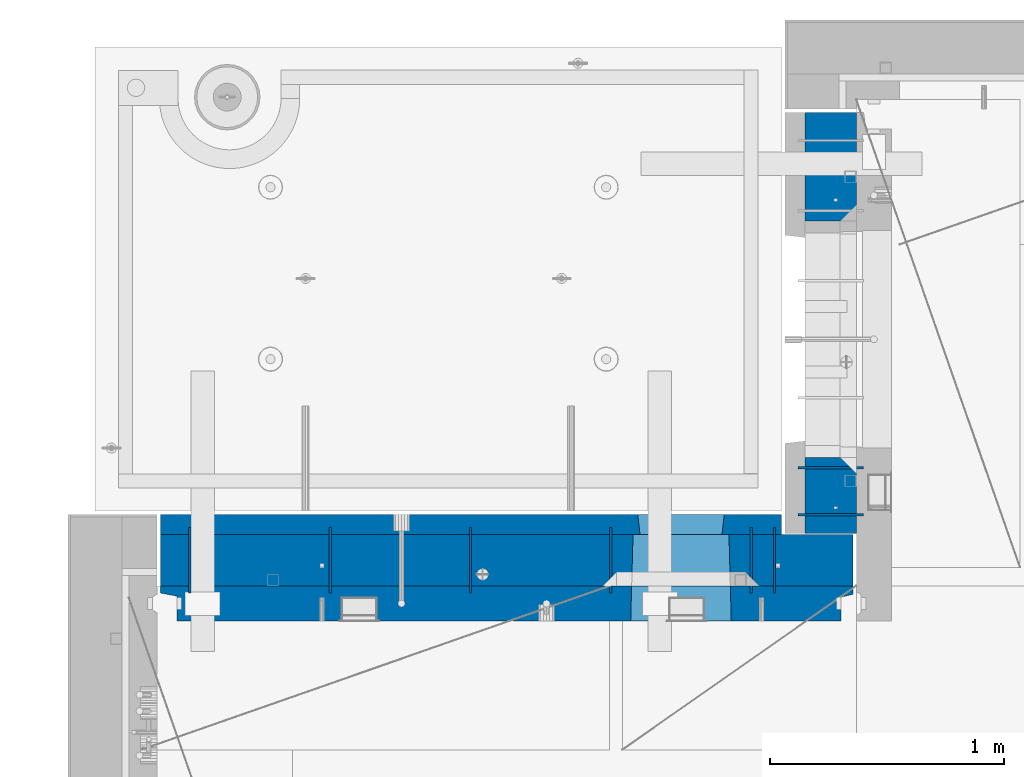
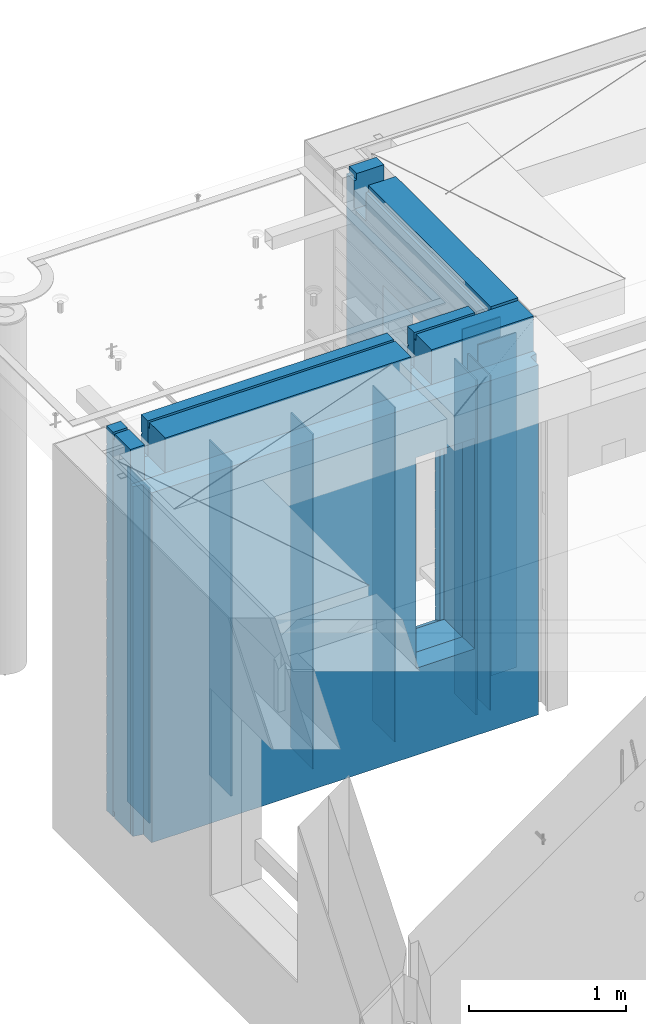
# One storey, part 225 of 334: 12 walls, 2 elements without a shape of their own.
"""IFC2X3 building model written with IfcOpenShell, lengths in millimetres."""

from ifc_helpers import new_model, si_unit, frame, origin_with_axes, place, context, subcontext, project, spatial, faceted_brep, material, type_object, element, aggregate, save


model = new_model("IFC2X3")

# Units and contexts
model_context = context("Model", 3, precision=1e-05, world=origin_with_axes())
body_context = subcontext(model_context, "Body", "Model", "MODEL_VIEW")
ifc_project = project(units=[si_unit("LENGTHUNIT", "METRE", prefix="MILLI"), si_unit("AREAUNIT", "SQUARE_METRE"), si_unit("VOLUMEUNIT", "CUBIC_METRE"), si_unit("MASSUNIT", "GRAM", prefix="KILO"), si_unit("TIMEUNIT", "SECOND"), si_unit("PLANEANGLEUNIT", "RADIAN"), si_unit("SOLIDANGLEUNIT", "STERADIAN"), si_unit("THERMODYNAMICTEMPERATUREUNIT", "DEGREE_CELSIUS"), si_unit("LUMINOUSINTENSITYUNIT", "LUMEN")], contexts=[model_context])

# Site, building, storey
site_placement = place(None, origin_with_axes())
site = spatial("IfcSite", under=ifc_project, at=site_placement, CompositionType="ELEMENT")
building_placement = place(site_placement, origin_with_axes())
building = spatial("IfcBuilding", under=site, at=building_placement, CompositionType="ELEMENT")
storey_placement = place(building_placement, origin_with_axes())
storey = spatial("IfcBuildingStorey", under=building, at=storey_placement, Name="3", CompositionType="ELEMENT", Elevation=0.0)

# Assembly, wall
assembly_1_placement = place(storey_placement, origin_with_axes())
assembly_1 = element("IfcElementAssembly", 1, at=assembly_1_placement, inside=storey, AssemblyPlace="NOTDEFINED", PredefinedType="REINFORCEMENT_UNIT")
ifc_material_1 = material(Name="Undefined")
wall_type_1 = type_object("IfcWallType", PredefinedType="NOTDEFINED")
wall_1_placement = place(assembly_1_placement, frame((11020.0, 20885.0002441406, 89115.0), z_axis=(0.0, 0.0, 1.0), x_axis=(-1.0, 3.00000001838171e-08, 0.0)))
wall_1 = element("IfcWall", 2, at=wall_1_placement, type_object=wall_type_1, material=ifc_material_1, Name="(PD)", context=body_context, shape_type="Brep", body=[
    faceted_brep([(0.0, 5.0, -1300.0), (0.0, 5.0, 1300.0), (280.0, 5.0, 1300.0), (280.0, 5.0, -1300.0), (0.0, -5.0, 1300.0), (280.0, -5.0, 1300.0), (0.0, -5.0, -1300.0), (280.0, -5.0, -1300.0)], [[[0, 1, 2, 3]], [[1, 4, 5, 2]], [[4, 6, 7, 5]], [[6, 0, 3, 7]], [[5, 7, 3, 2]], [[6, 4, 1, 0]]]),
])

assembly_2_placement = place(storey_placement, origin_with_axes())
assembly_2 = element("IfcElementAssembly", 3, at=assembly_2_placement, inside=storey, AssemblyPlace="NOTDEFINED", PredefinedType="REINFORCEMENT_UNIT")
wall_2_placement = place(assembly_2_placement, frame((10640.0002441406, 20549.9951872276, 89115.0), z_axis=(0.0, 0.0, 1.0), x_axis=(0.0, 1.0, 0.0)))
wall_2 = element("IfcWall", 4, at=wall_2_placement, type_object=wall_type_1, material=ifc_material_1, Name="(PD)", context=body_context, shape_type="Brep", body=[
    faceted_brep([(0.0, 5.0, -1300.0), (0.0, 5.0, 1300.0), (280.0, 5.0, 1300.0), (280.0, 5.0, -1300.0), (0.0, -5.0, 1300.0), (280.0, -5.0, 1300.0), (0.0, -5.0, -1300.0), (280.0, -5.0, -1300.0)], [[[0, 1, 2, 3]], [[1, 4, 5, 2]], [[4, 6, 7, 5]], [[6, 0, 3, 7]], [[5, 7, 3, 2]], [[6, 4, 1, 0]]]),
])

# Wall
wall_3_placement = place(assembly_1_placement, frame((11020.0, 21085.0002441406, 89115.0), z_axis=(0.0, 0.0, 1.0), x_axis=(-1.0, 3.00000001838171e-08, 0.0)))
wall_3 = element("IfcWall", 5, at=wall_3_placement, type_object=wall_type_1, material=ifc_material_1, Name="(PD)", context=body_context, shape_type="Brep", body=[
    faceted_brep([(0.0, 5.0, -1300.0), (0.0, 5.0, 1300.0), (280.0, 5.0, 1300.0), (280.0, 5.0, -1300.0), (0.0, -5.0, 1300.0), (280.0, -5.0, 1300.0), (0.0, -5.0, -1300.0), (280.0, -5.0, -1300.0)], [[[0, 1, 2, 3]], [[1, 4, 5, 2]], [[4, 6, 7, 5]], [[6, 0, 3, 7]], [[5, 7, 3, 2]], [[6, 4, 1, 0]]]),
])

wall_4_placement = place(assembly_2_placement, frame((8140.00024414063, 20549.9951872276, 89115.0), z_axis=(0.0, 0.0, 1.0), x_axis=(0.0, 1.0, 0.0)))
wall_4 = element("IfcWall", 6, at=wall_4_placement, type_object=wall_type_1, material=ifc_material_1, Name="(PD)", context=body_context, shape_type="Brep", body=[
    faceted_brep([(0.0, 5.0, -1300.0), (0.0, 5.0, 1300.0), (280.0, 5.0, 1300.0), (280.0, 5.0, -1300.0), (0.0, -5.0, 1300.0), (280.0, -5.0, 1300.0), (0.0, -5.0, -1300.0), (280.0, -5.0, -1300.0)], [[[0, 1, 2, 3]], [[1, 4, 5, 2]], [[4, 6, 7, 5]], [[6, 0, 3, 7]], [[5, 7, 3, 2]], [[6, 4, 1, 0]]]),
])

wall_5_placement = place(assembly_2_placement, frame((8740.00024414063, 20549.9951872276, 89115.0), z_axis=(0.0, 0.0, 1.0), x_axis=(0.0, 1.0, 0.0)))
wall_5 = element("IfcWall", 7, at=wall_5_placement, type_object=wall_type_1, material=ifc_material_1, Name="(PD)", context=body_context, shape_type="Brep", body=[
    faceted_brep([(0.0, 5.0, -1300.0), (0.0, 5.0, 1300.0), (280.0, 5.0, 1300.0), (280.0, 5.0, -1300.0), (0.0, -5.0, 1300.0), (280.0, -5.0, 1300.0), (0.0, -5.0, -1300.0), (280.0, -5.0, -1300.0)], [[[0, 1, 2, 3]], [[1, 4, 5, 2]], [[4, 6, 7, 5]], [[6, 0, 3, 7]], [[5, 7, 3, 2]], [[6, 4, 1, 0]]]),
])

wall_6_placement = place(assembly_2_placement, frame((9340.00024414063, 20549.9951872276, 89115.0), z_axis=(0.0, 0.0, 1.0), x_axis=(0.0, 1.0, 0.0)))
wall_6 = element("IfcWall", 8, at=wall_6_placement, type_object=wall_type_1, material=ifc_material_1, Name="(PD)", context=body_context, shape_type="Brep", body=[
    faceted_brep([(0.0, 5.0, -1300.0), (0.0, 5.0, 1300.0), (280.0, 5.0, 1300.0), (280.0, 5.0, -1300.0), (0.0, -5.0, 1300.0), (280.0, -5.0, 1300.0), (0.0, -5.0, -1300.0), (280.0, -5.0, -1300.0)], [[[0, 1, 2, 3]], [[1, 4, 5, 2]], [[4, 6, 7, 5]], [[6, 0, 3, 7]], [[5, 7, 3, 2]], [[6, 4, 1, 0]]]),
])

wall_7_placement = place(assembly_2_placement, frame((9940.00024414063, 20549.9951872276, 89115.0), z_axis=(0.0, 0.0, 1.0), x_axis=(0.0, 1.0, 0.0)))
wall_7 = element("IfcWall", 9, at=wall_7_placement, type_object=wall_type_1, material=ifc_material_1, Name="(PD)", context=body_context, shape_type="Brep", body=[
    faceted_brep([(0.0, 5.0, -1300.0), (0.0, 5.0, 1300.0), (280.0, 5.0, 1300.0), (280.0, 5.0, -1300.0), (0.0, -5.0, 1300.0), (280.0, -5.0, 1300.0), (0.0, -5.0, -1300.0), (280.0, -5.0, -1300.0)], [[[0, 1, 2, 3]], [[1, 4, 5, 2]], [[4, 6, 7, 5]], [[6, 0, 3, 7]], [[5, 7, 3, 2]], [[6, 4, 1, 0]]]),
])

wall_8_placement = place(assembly_2_placement, frame((10540.0002441406, 20549.9951872276, 89115.0), z_axis=(0.0, 0.0, 1.0), x_axis=(0.0, 1.0, 0.0)))
wall_8 = element("IfcWall", 10, at=wall_8_placement, type_object=wall_type_1, material=ifc_material_1, Name="(PD)", context=body_context, shape_type="Brep", body=[
    faceted_brep([(0.0, 5.0, -1300.0), (0.0, 5.0, 1300.0), (280.0, 5.0, 1300.0), (280.0, 5.0, -1300.0), (0.0, -5.0, 1300.0), (280.0, -5.0, 1300.0), (0.0, -5.0, -1300.0), (280.0, -5.0, -1300.0)], [[[0, 1, 2, 3]], [[1, 4, 5, 2]], [[4, 6, 7, 5]], [[6, 0, 3, 7]], [[5, 7, 3, 2]], [[6, 4, 1, 0]]]),
])

ifc_material_2 = material(Name="COS5gt")
wall_type_2 = type_object("IfcWallType", PredefinedType="NOTDEFINED")
wall_9_placement = place(assembly_1_placement, frame((10880.0, 20805.0, 89247.5), z_axis=(0.0, 0.0, 1.0), x_axis=(0.0, 1.0, 0.0)))
wall_9 = element("IfcWall", 11, at=wall_9_placement, type_object=wall_type_2, material=ifc_material_2, context=body_context, shape_type="Brep", body=[
    faceted_brep([(1800.0, -110.0, 1492.5), (1800.0, 90.0, 1492.5), (1705.0, 90.0, 1492.5), (1705.0, -110.0, 1492.5), (1800.0, 90.0, 1442.5), (1800.0, 110.0, 1442.5), (1705.0, 110.0, 1442.5), (1705.0, 90.0, 1442.5), (0.0, 110.0, 1442.5), (0.0, 90.0, 1442.5), (1555.0, 90.0, 1442.5), (1555.0, 110.0, 1442.5), (0.0, -110.0, -1492.5), (0.0, 90.0, -1492.5), (325.000271651108, 90.0, -1492.5), (325.000271651108, -110.0, -1492.5), (0.0, 90.0, -1442.5), (325.000271651108, 90.0, -1442.5), (0.0, -110.0, 1492.5), (0.0, 90.0, 1492.5), (0.0, 110.0, -1442.5), (325.000271651108, 110.0, -1442.5), (325.000271651108, 110.0, 857.5), (325.000271651108, -110.0, 857.5), (1335.00027165111, 110.0, 857.5), (1335.00027165111, -110.0, 857.5), (1555.0, 110.0, 1222.5), (1705.0, 110.0, 1222.5), (1800.0, 110.0, -1442.5), (1335.00027165111, 110.0, -1442.5), (1800.0, 90.0, -1442.5), (1800.0, 90.0, -1492.5), (1335.00027165111, 90.0, -1492.5), (1335.00027165111, 90.0, -1442.5), (1800.0, -110.0, -1492.5), (1335.00027165111, -110.0, -1492.5), (1705.0, -110.0, 1222.5), (1555.0, -110.0, 1222.5), (1555.0, -110.0, 1492.5), (1555.0, 90.0, 1492.5)], [[[0, 1, 2, 3]], [[4, 5, 6, 7]], [[8, 9, 10, 11]], [[12, 13, 14, 15]], [[13, 16, 17, 14]], [[13, 12, 18, 19, 9, 8, 20, 16]], [[16, 20, 21, 17]], [[15, 14, 17, 21, 22, 23]], [[23, 22, 24, 25]], [[21, 20, 8, 11, 26, 27, 6, 5, 28, 29, 24, 22]], [[30, 31, 32, 33]], [[28, 30, 33, 29]], [[5, 4, 1, 0, 34, 31, 30, 28]], [[31, 34, 35, 32]], [[25, 24, 29, 33, 32, 35]], [[34, 0, 3, 36, 37, 38, 18, 12, 15, 23, 25, 35]], [[19, 18, 38, 39]], [[9, 19, 39, 10]], [[38, 37, 26, 11, 10, 39]], [[36, 27, 26, 37]], [[3, 2, 7, 6, 27, 36]], [[1, 4, 7, 2]]]),
])

aggregate(assembly_1, [wall_1, wall_3, wall_9])

wall_10_placement = place(assembly_2_placement, frame((8000.0, 20689.9951872276, 89247.5), z_axis=(0.0, 0.0, 1.0), x_axis=(1.0, 0.0, 0.0)))
wall_10 = element("IfcWall", 12, at=wall_10_placement, type_object=wall_type_2, material=ifc_material_2, context=body_context, shape_type="Brep", body=[
    faceted_brep([(2075.0, 110.0, 1442.5), (2075.0, 90.0, 1442.5), (2075.0, 90.0, 1492.5), (2075.0, -110.0, 1492.5), (2075.0, -110.000000000004, 1222.5), (2075.0, 109.999999999996, 1222.5), (2225.0, -110.000000000004, 1222.5), (2225.0, 109.999999999996, 1222.5), (2225.0, 110.0, 1442.5), (2225.0, -110.0, 1492.5), (2225.0, 90.0, 1492.5), (2225.0, 90.0, 1442.5), (2975.0, 90.0, -1492.5), (15.0, 90.0, -1492.5), (15.0, 90.0, -1442.5), (2975.0, 90.0, -1442.5), (2975.0, -110.0, -1492.5), (15.0, -110.0, -1492.5), (15.0, 90.0, 1442.5), (15.0, 90.0, 1492.5), (119.999999999998, 90.0, 1492.5), (119.999999999998, 90.0, 1442.5), (15.0, -110.0, 1492.5), (119.999999999998, -110.0, 1492.5), (269.999999999998, 110.0, 1442.5), (269.999999999998, 90.0, 1442.5), (269.999999999998, 90.0, 1492.5), (269.999999999998, -110.0, 1492.5), (269.999999999998, 110.0, 1222.5), (269.999999999998, -110.0, 1222.5), (119.999999999998, 110.0, 1222.5), (119.999999999998, -110.0, 1222.5), (119.999999999998, 110.0, 1442.5), (15.0, 110.0, 1442.5), (15.0, 110.0, -1442.5), (2975.0, 110.0, -1442.5), (2975.0, 110.0, 1442.5), (2975.0, 90.0, 1442.5), (2975.0, 90.0, 1492.5), (2975.0, -110.0, 1492.5), (2029.05276420954, -110.0, -813.445945945947), (2029.05276420954, -110.0, 813.445945945947), (2450.94465610143, -110.0, 813.445945945947), (2450.94465610143, -110.0, -813.445945945947), (2034.99871015549, 110.0, -802.5), (2034.99871015549, 110.0, 807.5), (2034.99871015549, 110.0, -807.5), (2444.99871015549, 110.0, -807.5), (2414.99871015549, 110.0, -807.5), (2064.99871015549, 110.0, -807.5), (2444.99871015549, 110.0, 807.5), (2444.99871015549, 110.0, -802.5)], [[[0, 1, 2, 3, 4, 5]], [[5, 4, 6, 7]], [[8, 7, 6, 9, 10, 11]], [[12, 13, 14, 15]], [[16, 17, 13, 12]], [[18, 19, 20, 21]], [[19, 22, 23, 20]], [[24, 25, 1, 0]], [[26, 27, 3, 2]], [[25, 26, 2, 1]], [[24, 28, 29, 27, 26, 25]], [[30, 31, 29, 28]], [[32, 21, 20, 23, 31, 30]], [[33, 18, 21, 32]], [[13, 17, 22, 19, 18, 33, 34, 14]], [[35, 15, 14, 34]], [[36, 37, 38, 39, 16, 12, 15, 35]], [[37, 36, 8, 11]], [[38, 37, 11, 10]], [[39, 38, 10, 9]], [[4, 3, 27, 29, 31, 23, 22, 17, 16, 39, 9, 6], [40, 41, 42, 43]], [[44, 45, 41, 40, 46]], [[43, 47, 48, 49, 46, 40]], [[42, 50, 51, 47, 43]], [[41, 45, 50, 42]], [[36, 35, 34, 33, 32, 30, 28, 24, 0, 5, 7, 8], [44, 46, 49, 48, 47, 51, 50, 45]]]),
])

ifc_material_3 = material(Name="CONCRETE/C30/37")
wall_type_3 = type_object("IfcWallType", PredefinedType="NOTDEFINED")
wall_11_placement = place(assembly_2_placement, frame((8000.0, 20842.4951872276, 89247.5), z_axis=(0.0, 0.0, 1.0), x_axis=(1.0, 0.0, 0.0)))
wall_11 = element("IfcWall", 13, at=wall_11_placement, type_object=wall_type_3, material=ifc_material_3, context=body_context, shape_type="Brep", body=[
    faceted_brep([(2075.0, 42.5, 1492.5), (2075.0, -42.5, 1492.5), (2075.0, -42.5000000000036, 1222.5), (2075.0, 42.4999994593163, 1222.5), (2075.0, 42.4999996925035, 1342.99999994476), (2075.0, 32.4999992506928, 1344.9999999992), (2075.0, 32.4999991126933, 1355.00000040043), (2075.0, 42.4999994127757, 1356.99999988925), (2225.0, -42.5000000000036, 1222.5), (2225.0, 42.4999994264763, 1222.5), (2225.0, 42.5, 1492.5), (2225.0, 42.4999993700148, 1356.99999988925), (2225.0, 32.4999991126933, 1355.00000040043), (2225.0, 32.4999992506928, 1344.9999999992), (2225.0, 42.4999996701117, 1342.99999994476), (2225.0, -42.5, 1492.5), (2054.99871015549, 42.5, -857.5), (2064.99871015549, -42.5, -807.5), (2414.99871015549, -42.5, -807.5), (2424.99871015549, 42.5, -857.5), (15.0, 42.5, -757.000000055239), (15.0, 32.4999992506928, -755.0000000008), (2056.17518083188, 32.4999992506928, -755.0000000008), (2054.99871015549, 42.4999994516256, -757.000000055239), (15.0, 32.4999991126933, -744.999999599575), (2056.17518084811, 32.4999991126933, -744.999999599575), (15.0, 42.5, -743.000000110755), (2054.99871015549, 42.4999994184764, -743.000000110755), (15.0, 42.5, -607.000000055239), (2054.99871015549, 42.4999994538521, -607.000000055239), (15.0, 32.4999992506928, -605.0000000008), (2056.17518083188, 32.4999992506928, -605.0000000008), (15.0, 32.4999991126933, -594.999999599575), (2056.17518084811, 32.4999991126933, -594.999999599575), (15.0, 42.5, -593.000000110755), (2054.99871015549, 42.4999994184764, -593.000000110755), (15.0, 42.5, -457.000000055239), (2054.99871015549, 42.4999994563987, -457.000000055239), (15.0000000000009, 32.4999992506928, -455.0000000008), (2056.17518083188, 32.4999992506928, -455.0000000008), (15.0000000000009, 32.4999991126933, -444.999999599575), (2056.17518084811, 32.4999991126933, -444.999999599575), (15.0, 42.5, -443.000000110755), (2054.99871015549, 42.4999994184764, -443.000000110755), (15.0, 42.5, -307.000000055239), (2054.99871015549, 42.4999994593381, -307.000000055239), (15.0, 32.4999992506928, -305.0000000008), (2056.17518083188, 32.4999992506928, -305.0000000008), (15.0, 32.4999991126933, -294.999999599575), (2056.17518084811, 32.4999991126933, -294.999999599575), (15.0, 42.5, -293.000000110755), (2054.99871015549, 42.4999994184764, -293.000000110755), (15.0, 42.5, -157.000000055239), (2054.99871015549, 42.4999994627688, -157.000000055239), (15.0000000000009, 32.4999992506928, -155.0000000008), (2056.17518083188, 32.4999992506928, -155.0000000008), (15.0000000000009, 32.4999991126933, -144.999999599575), (2056.17518084811, 32.4999991126933, -144.999999599575), (15.0, 42.5, -143.000000110755), (2054.99871015549, 42.4999994184764, -143.000000110755), (15.0, 42.5, -7.00000005523907), (2054.99871015549, 42.4999994668287, -7.00000005523907), (14.9999999999991, 32.4999992506928, -5.00000000080036), (2056.17518083188, 32.4999992506928, -5.00000000080036), (14.9999999999991, 32.4999991126933, 5.00000040042505), (2056.17518084811, 32.4999991126933, 5.00000040042505), (15.0, 42.5, 6.99999988924537), (2054.99871015549, 42.4999994184764, 6.99999988924537), (15.0, 42.5, 142.999999944761), (2054.99871015549, 42.4999994717145, 142.999999944761), (15.0000000000009, 32.4999992506928, 144.9999999992), (2056.17518083188, 32.4999992506928, 144.9999999992), (15.0000000000009, 32.4999991126933, 155.000000400425), (2056.17518084811, 32.4999991126933, 155.000000400425), (15.0, 42.5, 156.999999889245), (2054.99871015549, 42.4999994184764, 156.999999889245), (15.0, 42.5, 292.999999944761), (2054.99871015549, 42.4999994776954, 292.999999944761), (15.0, 32.4999992506928, 294.9999999992), (2056.17518083188, 32.4999992506928, 294.9999999992), (15.0, 32.4999991126933, 305.000000400425), (2056.17518084811, 32.4999991126933, 305.000000400425), (15.0, 42.5, 306.999999889245), (2054.99871015549, 42.4999994184764, 306.999999889245), (15.0, 42.5, 442.999999944761), (2054.99871015549, 42.499999485186, 442.999999944761), (15.0, 32.4999992506928, 444.9999999992), (2056.17518083188, 32.4999992506928, 444.9999999992), (15.0, 32.4999991126933, 455.000000400425), (2056.17518084811, 32.4999991126933, 455.000000400425), (15.0, 42.5, 456.999999889245), (2054.99871015549, 42.4999994184764, 456.999999889245), (15.0, 42.5, 592.999999944761), (2054.99871015549, 42.4999994948485, 592.999999944761), (15.0, 32.4999992506928, 594.9999999992), (2056.17518083188, 32.4999992506928, 594.9999999992), (15.0, 32.4999991126933, 605.000000400425), (2056.17518084811, 32.4999991126933, 605.000000400425), (15.0, 42.5, 606.999999889245), (2054.99871015549, 42.4999994184764, 606.999999889245), (15.0, 42.5, 742.999999944761), (2054.99871015549, 42.4999995077887, 742.999999944761), (15.0, 32.4999992506928, 744.9999999992), (2056.17518083188, 32.4999992506928, 744.9999999992), (15.0, 32.4999991126933, 755.000000400425), (2056.17518084811, 32.4999991126933, 755.000000400425), (15.0, 42.5, 756.999999889245), (2054.99871015549, 42.4999994184764, 756.999999889245), (2670.0, 32.4999992506928, 1194.9999999992), (15.0000000000009, 32.4999992506928, 1194.9999999992), (15.0000000000009, 32.4999991126933, 1205.00000040043), (2670.0, 32.4999991126933, 1205.00000040043), (2670.0, 42.4999994795107, 1192.99999994476), (15.0, 42.5, 1192.99999994476), (2670.0, 42.4999992431622, 1056.99999988925), (15.0, 42.5, 1056.99999988925), (2670.0, 32.4999991126933, 1055.00000040043), (15.0, 32.4999991126933, 1055.00000040043), (2670.0, 32.4999992506928, 1044.9999999992), (15.0, 32.4999992506928, 1044.9999999992), (2670.0, 42.4999994189602, 1042.99999994476), (15.0, 42.5, 1042.99999994476), (2670.0, 42.4999992431622, 906.999999889245), (15.0, 42.5, 906.999999889245), (2670.0, 32.4999991126933, 905.000000400425), (15.0, 32.4999991126933, 905.000000400425), (2670.0, 32.4999992506928, 894.9999999992), (15.0, 32.4999992506928, 894.9999999992), (2670.0, 42.4999993831079, 892.999999944761), (15.0, 42.5, 892.999999944761), (2670.0, 32.4999992506928, -755.0000000008), (2670.0, 42.4999992863086, -757.000000055239), (2424.99871015549, 42.4999993521669, -757.000000055239), (2423.8222394791, 32.4999992506928, -755.0000000008), (2670.0, 32.4999991126933, -744.999999599575), (2423.82223946286, 32.4999991126933, -744.999999599575), (2670.0, 42.4999992431622, -743.000000110755), (2424.99871015549, 42.4999993130041, -743.000000110755), (2670.0, 42.4999992892044, -607.000000055239), (2424.99871015549, 42.4999993547972, -607.000000055239), (2670.0, 32.4999992506928, -605.0000000008), (2423.8222394791, 32.4999992506928, -605.0000000008), (2670.0, 32.4999991126933, -594.999999599575), (2423.82223946286, 32.4999991126933, -594.999999599575), (2670.0, 42.4999992431622, -593.000000110755), (2424.99871015549, 42.4999993130041, -593.000000110755), (2670.0, 42.4999992925186, -457.000000055239), (2424.99871015549, 42.4999993578058, -457.000000055239), (2670.0, 32.4999992506928, -455.0000000008), (2423.8222394791, 32.4999992506928, -455.0000000008), (2670.0, 32.4999991126933, -444.999999599575), (2423.82223946286, 32.4999991126933, -444.999999599575), (2670.0, 42.4999992431622, -443.000000110755), (2424.99871015549, 42.4999993130041, -443.000000110755), (2670.0, 42.4999992963421, -307.000000055239), (2424.99871015549, 42.4999993612764, -307.000000055239), (2670.0, 32.4999992506928, -305.0000000008), (2423.8222394791, 32.4999992506928, -305.0000000008), (2670.0, 32.4999991126933, -294.999999599575), (2423.82223946286, 32.4999991126933, -294.999999599575), (2670.0, 42.4999992431622, -293.000000110755), (2424.99871015549, 42.4999993130041, -293.000000110755), (2670.0, 42.4999993008096, -157.000000055239), (2424.99871015549, 42.4999993653291, -157.000000055239), (2670.0, 32.4999992506928, -155.0000000008), (2423.8222394791, 32.4999992506928, -155.0000000008), (2670.0, 32.4999991126933, -144.999999599575), (2423.82223946286, 32.4999991126933, -144.999999599575), (2670.0, 42.4999992431622, -143.000000110755), (2424.99871015549, 42.4999993130041, -143.000000110755), (2670.0, 42.4999993060956, -7.00000005523907), (2424.99871015549, 42.4999993701276, -7.00000005523907), (2670.0, 32.4999992506928, -5.00000000080036), (2423.8222394791, 32.4999992506928, -5.00000000080036), (2670.0, 32.4999991126933, 5.00000040042505), (2423.82223946286, 32.4999991126933, 5.00000040042505), (2670.0, 42.4999992431622, 6.99999988924537), (2424.99871015549, 42.4999993130041, 6.99999988924537), (2670.0, 42.4999993124511, 142.999999944761), (2424.99871015549, 42.4999993758975, 142.999999944761), (2670.0, 32.4999992506928, 144.9999999992), (2423.8222394791, 32.4999992506928, 144.9999999992), (2670.0, 32.4999991126933, 155.000000400425), (2423.82223946286, 32.4999991126933, 155.000000400425), (2670.0, 42.4999992431622, 156.999999889245), (2424.99871015549, 42.4999993130041, 156.999999889245), (2670.0, 42.4999993202327, 292.999999944761), (2424.99871015549, 42.4999993829624, 292.999999944761), (2670.0, 32.4999992506928, 294.9999999992), (2423.8222394791, 32.4999992506928, 294.9999999992), (2670.0, 32.4999991126933, 305.000000400425), (2423.82223946286, 32.4999991126933, 305.000000400425), (2670.0, 42.4999992431622, 306.999999889245), (2424.99871015549, 42.4999993130041, 306.999999889245), (2670.0, 42.4999993299862, 442.999999944761), (2424.99871015549, 42.4999993918136, 442.999999944761), (2670.0, 32.4999992506928, 444.9999999992), (2423.8222394791, 32.4999992506928, 444.9999999992), (2670.0, 32.4999991126933, 455.000000400425), (2423.82223946286, 32.4999991126933, 455.000000400425), (2670.0, 42.4999992431622, 456.999999889245), (2424.99871015549, 42.4999993130041, 456.999999889245), (2670.0, 42.4999993425627, 592.999999944761), (2424.99871015549, 42.4999994032296, 592.999999944761), (2670.0, 32.4999992506928, 594.9999999992), (2423.8222394791, 32.4999992506928, 594.9999999992), (2670.0, 32.4999991126933, 605.000000400425), (2423.82223946286, 32.4999991126933, 605.000000400425), (2670.0, 42.4999992431622, 606.999999889245), (2424.99871015549, 42.4999993130041, 606.999999889245), (2670.0, 42.4999993594029, 742.999999944761), (2424.99871015549, 42.4999994185164, 742.999999944761), (2670.0, 32.4999992506928, 744.9999999992), (2423.8222394791, 32.4999992506928, 744.9999999992), (2670.0, 32.4999991126933, 755.000000400425), (2423.82223946286, 32.4999991126933, 755.000000400425), (2670.0, 42.4999992431622, 756.999999889245), (2424.99871015549, 42.4999993130041, 756.999999889245), (2064.99871015549, 42.5, 782.5), (2054.99871015549, 42.5, 782.5), (2424.99871015549, 42.5, 782.5), (2414.99871015549, 42.5, 782.5), (2064.99871015549, -42.5, 782.5), (2064.99871015549, -42.5, 787.5), (2414.99871015549, -42.5, 787.5), (2414.99871015549, -42.5, 782.5), (2670.0, 42.4999992431622, -893.000000110755), (15.0, 42.5, -893.000000110755), (2670.0, 32.4999991126933, -894.999999599575), (15.0000000000009, 32.4999991126933, -894.999999599575), (2670.0, 32.4999992506928, -905.0000000008), (15.0000000000009, 32.4999992506928, -905.0000000008), (2670.0, 42.4999992837584, -907.000000055239), (15.0, 42.5, -907.000000055239), (2670.0, 42.4999992431622, -1043.00000011075), (15.0, 42.5, -1043.00000011075), (2670.0, 32.4999991126933, -1044.99999959957), (15.0, 32.4999991126933, -1044.99999959957), (2670.0, 32.4999992506928, -1055.0000000008), (15.0, 32.4999992506928, -1055.0000000008), (2670.0, 42.4999992814919, -1057.00000005524), (15.0, 42.5, -1057.00000005524), (2670.0, 42.4999992431622, -1193.00000011075), (15.0, 42.5, -1193.00000011075), (2670.0, 32.4999991126933, -1194.99999959957), (15.0, 32.4999991126933, -1194.99999959957), (2670.0, 32.4999992506928, -1205.0000000008), (15.0, 32.4999992506928, -1205.0000000008), (2670.0, 42.4999992794619, -1207.00000005524), (15.0, 42.5, -1207.00000005524), (2670.0, 42.4999992431622, -1343.00000011075), (15.0, 42.5, -1343.00000011075), (2670.0, 32.4999991126933, -1344.99999959957), (15.0, 32.4999991126933, -1344.99999959957), (2670.0, 32.4999992506928, -1355.0000000008), (15.0, 32.4999992506928, -1355.0000000008), (2670.0, 42.5, -1357.00000005524), (15.0, 42.5, -1357.00000005524), (2670.0, 42.5, -1492.5), (15.0, 42.5, -1492.5), (15.0, -42.5, -1492.5), (2670.0, -42.5, -1492.5), (15.0, 42.5, 1356.99999988925), (15.0, 42.5, 1492.5), (119.999999999998, 42.5, 1492.5), (119.999999999998, 42.4999999700703, 1356.99999988925), (15.0, -42.5, 1492.5), (119.999999999998, -42.5, 1492.5), (269.999999999998, 42.5, 1492.5), (269.999999999998, 42.4999999273095, 1356.99999988925), (269.999999999998, 32.4999991126933, 1355.00000040043), (269.999999999998, 32.4999992506928, 1344.9999999992), (269.999999999998, 42.4999999619358, 1342.99999994476), (269.999999999998, 42.4999998750354, 1222.5), (269.999999999998, -42.5, 1222.5), (269.999999999998, -42.5, 1492.5), (119.999999999998, 42.4999999076099, 1222.5), (119.999999999998, -42.5, 1222.5), (15.0, 42.5, 1342.99999994476), (15.0, 32.4999992506928, 1344.9999999992), (119.999999999998, 32.4999992506928, 1344.9999999992), (119.999999999998, 42.4999999843276, 1342.99999994476), (15.0, 32.4999991126933, 1355.00000040043), (119.999999999998, 32.4999991126933, 1355.00000040043), (15.0, 42.5, 1206.99999988925), (2670.0, 42.4999992431622, 1206.99999988925), (2670.0, 42.5, 1492.5), (2670.0, -42.5, 1492.5), (2670.0, 42.4999996036859, 1342.99999994476), (2670.0, 32.4999992506928, 1344.9999999992), (2670.0, 32.4999991126933, 1355.00000040043), (2670.0, 42.4999992431622, 1356.99999988925)], [[[0, 1, 2, 3, 4, 5, 6, 7]], [[3, 2, 8, 9]], [[10, 11, 12, 13, 14, 9, 8, 15]], [[16, 17, 18, 19]], [[20, 21, 22, 23]], [[21, 24, 25, 22]], [[24, 26, 27, 25]], [[26, 28, 29, 27]], [[28, 30, 31, 29]], [[30, 32, 33, 31]], [[32, 34, 35, 33]], [[34, 36, 37, 35]], [[36, 38, 39, 37]], [[38, 40, 41, 39]], [[40, 42, 43, 41]], [[42, 44, 45, 43]], [[44, 46, 47, 45]], [[46, 48, 49, 47]], [[48, 50, 51, 49]], [[50, 52, 53, 51]], [[52, 54, 55, 53]], [[54, 56, 57, 55]], [[56, 58, 59, 57]], [[58, 60, 61, 59]], [[60, 62, 63, 61]], [[62, 64, 65, 63]], [[64, 66, 67, 65]], [[66, 68, 69, 67]], [[68, 70, 71, 69]], [[70, 72, 73, 71]], [[72, 74, 75, 73]], [[74, 76, 77, 75]], [[76, 78, 79, 77]], [[78, 80, 81, 79]], [[80, 82, 83, 81]], [[82, 84, 85, 83]], [[84, 86, 87, 85]], [[86, 88, 89, 87]], [[88, 90, 91, 89]], [[90, 92, 93, 91]], [[92, 94, 95, 93]], [[94, 96, 97, 95]], [[96, 98, 99, 97]], [[98, 100, 101, 99]], [[100, 102, 103, 101]], [[102, 104, 105, 103]], [[104, 106, 107, 105]], [[108, 109, 110, 111]], [[112, 113, 109, 108]], [[114, 115, 113, 112]], [[114, 116, 117, 115]], [[118, 119, 117, 116]], [[120, 121, 119, 118]], [[122, 123, 121, 120]], [[122, 124, 125, 123]], [[126, 127, 125, 124]], [[128, 129, 127, 126]], [[130, 131, 132, 133]], [[134, 130, 133, 135]], [[136, 134, 135, 137]], [[138, 136, 137, 139]], [[140, 138, 139, 141]], [[142, 140, 141, 143]], [[144, 142, 143, 145]], [[146, 144, 145, 147]], [[148, 146, 147, 149]], [[150, 148, 149, 151]], [[152, 150, 151, 153]], [[154, 152, 153, 155]], [[156, 154, 155, 157]], [[158, 156, 157, 159]], [[160, 158, 159, 161]], [[162, 160, 161, 163]], [[164, 162, 163, 165]], [[166, 164, 165, 167]], [[168, 166, 167, 169]], [[170, 168, 169, 171]], [[172, 170, 171, 173]], [[174, 172, 173, 175]], [[176, 174, 175, 177]], [[178, 176, 177, 179]], [[180, 178, 179, 181]], [[182, 180, 181, 183]], [[184, 182, 183, 185]], [[186, 184, 185, 187]], [[188, 186, 187, 189]], [[190, 188, 189, 191]], [[192, 190, 191, 193]], [[194, 192, 193, 195]], [[196, 194, 195, 197]], [[198, 196, 197, 199]], [[200, 198, 199, 201]], [[202, 200, 201, 203]], [[204, 202, 203, 205]], [[206, 204, 205, 207]], [[208, 206, 207, 209]], [[210, 208, 209, 211]], [[212, 210, 211, 213]], [[214, 212, 213, 215]], [[216, 214, 215, 217]], [[218, 219, 107, 106, 129, 128, 216, 217, 220, 221]], [[222, 17, 16, 23, 22, 25, 27, 29, 31, 33, 35, 37, 39, 41, 43, 45, 47, 49, 51, 53, 55, 57, 59, 61, 63, 65, 67, 69, 71, 73, 75, 77, 79, 81, 83, 85, 87, 89, 91, 93, 95, 97, 99, 101, 103, 105, 107, 219, 223]], [[218, 221, 220, 224, 223, 219]], [[217, 215, 213, 211, 209, 207, 205, 203, 201, 199, 197, 195, 193, 191, 189, 187, 185, 183, 181, 179, 177, 175, 173, 171, 169, 167, 165, 163, 161, 159, 157, 155, 153, 151, 149, 147, 145, 143, 141, 139, 137, 135, 133, 132, 19, 18, 225, 224, 220]], [[131, 226, 227, 20, 23, 16, 19, 132]], [[226, 228, 229, 227]], [[230, 231, 229, 228]], [[232, 233, 231, 230]], [[234, 235, 233, 232]], [[234, 236, 237, 235]], [[238, 239, 237, 236]], [[240, 241, 239, 238]], [[242, 243, 241, 240]], [[242, 244, 245, 243]], [[246, 247, 245, 244]], [[248, 249, 247, 246]], [[250, 251, 249, 248]], [[250, 252, 253, 251]], [[254, 255, 253, 252]], [[256, 257, 255, 254]], [[258, 259, 257, 256]], [[260, 259, 258, 261]], [[262, 263, 264, 265]], [[263, 266, 267, 264]], [[268, 269, 270, 271, 272, 273, 274, 275]], [[276, 277, 274, 273]], [[278, 279, 280, 281]], [[279, 282, 283, 280]], [[264, 267, 277, 276, 281, 280, 283, 265]], [[282, 262, 265, 283]], [[279, 278, 284, 110, 109, 113, 115, 117, 119, 121, 123, 125, 127, 129, 106, 104, 102, 100, 98, 96, 94, 92, 90, 88, 86, 84, 82, 80, 78, 76, 74, 72, 70, 68, 66, 64, 62, 60, 58, 56, 54, 52, 50, 48, 46, 44, 42, 40, 38, 36, 34, 32, 30, 28, 26, 24, 21, 20, 227, 229, 231, 233, 235, 237, 239, 241, 243, 245, 247, 249, 251, 253, 255, 257, 259, 260, 266, 263, 262, 282]], [[285, 111, 110, 284]], [[286, 287, 261, 258, 256, 254, 252, 250, 248, 246, 244, 242, 240, 238, 236, 234, 232, 230, 228, 226, 131, 130, 134, 136, 138, 140, 142, 144, 146, 148, 150, 152, 154, 156, 158, 160, 162, 164, 166, 168, 170, 172, 174, 176, 178, 180, 182, 184, 186, 188, 190, 192, 194, 196, 198, 200, 202, 204, 206, 208, 210, 212, 214, 216, 128, 126, 124, 122, 120, 118, 116, 114, 112, 108, 111, 285, 288, 289, 290, 291]], [[287, 286, 10, 15]], [[2, 1, 275, 274, 277, 267, 266, 260, 261, 287, 15, 8], [18, 17, 222, 223, 224, 225]], [[268, 275, 1, 0]], [[269, 268, 0, 7]], [[270, 269, 7, 6]], [[271, 270, 6, 5]], [[272, 271, 5, 4]], [[288, 285, 284, 278, 281, 276, 273, 272, 4, 3, 9, 14]], [[289, 288, 14, 13]], [[290, 289, 13, 12]], [[291, 290, 12, 11]], [[286, 291, 11, 10]]]),
])

ifc_material_4 = material(Name="CONCRETE/C25/30")
wall_type_4 = type_object("IfcWallType", PredefinedType="NOTDEFINED")
wall_12_placement = place(assembly_2_placement, frame((8000.0, 20504.9951872276, 89112.5), z_axis=(0.0, 0.0, 1.0), x_axis=(1.0, 0.0, 0.0)))
wall_12 = element("IfcWall", 14, at=wall_12_placement, type_object=wall_type_4, material=ifc_material_4, context=body_context, shape_type="Brep", body=[
    faceted_brep([(2925.0, -75.0, 1357.5), (2925.0, -75.0, -1357.5), (2925.0, 27.0, -1357.5), (2925.0, 27.0, 1357.5), (2975.0, 75.0, 1357.5), (15.0, 75.0, 1357.5), (15.0, 45.0, 1357.5), (85.0, 32.0, 1357.5), (85.0, -75.0, 1357.5), (2975.0, 40.0, 1357.5), (85.0, 32.0, -1357.5), (85.0, -75.0, -1357.5), (15.0, 45.0, -1357.5), (15.0, 75.0, -1357.5), (2975.0, 75.0, -1357.5), (2975.0, 40.0, -1357.5), (2024.99871015549, -75.0, 952.5), (2029.05276420954, 75.0, 948.445945945947), (2450.94465610143, 75.0, 948.445945945947), (2454.99871015549, -75.0, 952.5), (2029.05276420954, 75.0, -678.445945945947), (2450.94465610143, 75.0, -678.445945945947), (2454.99871015549, -75.0, -682.5), (2024.99871015549, -75.0, -682.5)], [[[0, 1, 2, 3]], [[4, 5, 6, 7, 8, 0, 3, 9]], [[7, 10, 11, 8]], [[6, 12, 10, 7]], [[5, 13, 12, 6]], [[1, 11, 10, 12, 13, 14, 15, 2]], [[9, 3, 2, 15]], [[14, 4, 9, 15]], [[16, 17, 18, 19]], [[13, 5, 4, 14], [20, 21, 18, 17]], [[19, 18, 21, 22]], [[8, 11, 1, 0], [23, 16, 19, 22]], [[17, 16, 23, 20]], [[22, 21, 20, 23]]]),
])

aggregate(assembly_2, [wall_2, wall_4, wall_5, wall_6, wall_7, wall_8, wall_11, wall_10, wall_12])

save(model, "model.ifc")
